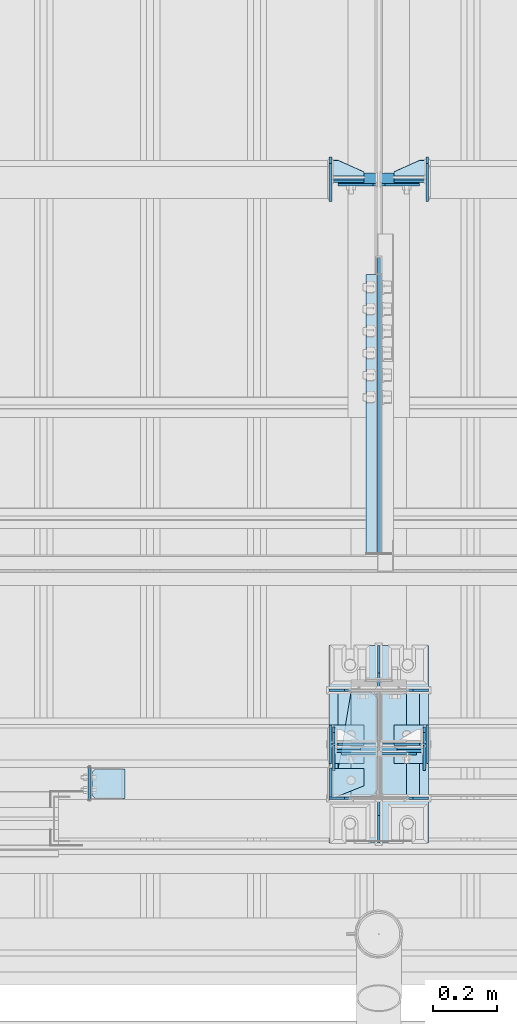
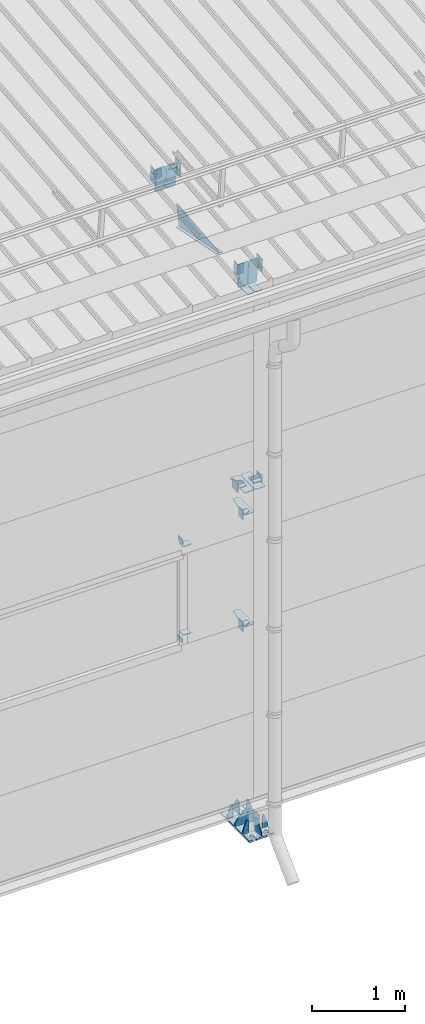
# One storey, part 143 of 709: 45 plates, 4 openings, 11 elements without a shape of their own.
"""IFC4 building model written with IfcOpenShell, lengths in millimetres."""

from ifc_helpers import new_model, si_unit, direction, frame, origin_with_axes, place, context, subcontext, project, spatial, line, arc, indexed_curve, outline, extrude, material, element, aggregate, save


model = new_model("IFC4")

# Units and contexts
model_context = context("Model", 3, precision=0.2, world=origin_with_axes(), true_north=direction((0.0, 1.0)))
body_context = subcontext(model_context, "Body", "Model", "MODEL_VIEW")
ifc_project = project(units=[si_unit("LENGTHUNIT", "METRE", prefix="MILLI"), si_unit("AREAUNIT", "SQUARE_METRE"), si_unit("VOLUMEUNIT", "CUBIC_METRE"), si_unit("MASSUNIT", "GRAM", prefix="KILO"), si_unit("TIMEUNIT", "SECOND"), si_unit("PLANEANGLEUNIT", "RADIAN"), si_unit("SOLIDANGLEUNIT", "STERADIAN"), si_unit("THERMODYNAMICTEMPERATUREUNIT", "DEGREE_CELSIUS"), si_unit("LUMINOUSINTENSITYUNIT", "LUMEN")], contexts=[model_context])

# Site, building, storey
site_placement = place(None, origin_with_axes())
site = spatial("IfcSite", under=ifc_project, at=site_placement, CompositionType="ELEMENT")
building_placement = place(site_placement, origin_with_axes())
building = spatial("IfcBuilding", under=site, at=building_placement, Name="Undefined", CompositionType="ELEMENT")
storey_placement = place(building_placement, origin_with_axes())
storey = spatial("IfcBuildingStorey", under=building, at=storey_placement, Name="Undefined", CompositionType="ELEMENT", Elevation=0.0)

# Assembly, plates, voiding features
assembly_1_placement = place(storey_placement, frame((34000.0, 173.0, -200.0), z_axis=(-1.0, 0.0, 0.0), x_axis=(0.0, 0.0, 1.0)))
assembly_1 = element("IfcElementAssembly", 1, at=assembly_1_placement, inside=storey)
ifc_material = material(Name="C355-6", Category="STEEL")
plate_1_placement = place(assembly_1_placement, frame((7434.21546, -30.02526, -3.0), z_axis=(0.099503719, 0.9950371902, 0.0), x_axis=(0.0, 0.0, -1.0)))
plate_1 = element("IfcPlate", 2, at=plate_1_placement, material=ifc_material, ObjectType="595", context=body_context, shape_type="SolidModel", body=[
    extrude(outline(indexed_curve([(0.0, 0.0), (114.0, 0.0), (114.0, 332.53554), (0.0, 332.53554)], segments=[line(1, 2, 3, 4, 1)])), frame((0.0, 0.0, 4.0), z_axis=(0.0, 0.0, 1.0), x_axis=(1.0, 0.0, 0.0)), (0.0, 0.0, -1.0), 8.0),
])
plate_2_placement = place(assembly_1_placement, frame((7434.21546, -30.02526, 3.0), z_axis=(-0.099503719, -0.9950371902, 0.0), x_axis=(0.0, 0.0, 1.0)))
plate_2 = element("IfcPlate", 3, at=plate_2_placement, material=ifc_material, ObjectType="595", context=body_context, shape_type="SolidModel", body=[
    extrude(outline(indexed_curve([(0.0, 0.0), (114.0, 0.0), (114.0, 333.33554), (0.0, 333.33554)], segments=[line(1, 2, 3, 4, 1)])), frame((0.0, 0.0, 4.0), z_axis=(0.0, 0.0, 1.0), x_axis=(1.0, 0.0, 0.0)), (0.0, 0.0, -1.0), 8.0),
])
plate_3_placement = place(assembly_1_placement, frame((4502.0, -163.0, -127.0), z_axis=(-1.0, 0.0, 0.0), x_axis=(0.0, 0.0, 1.0)))
plate_3 = element("IfcPlate", 4, at=plate_3_placement, material=ifc_material, ObjectType="547", context=body_context, shape_type="SolidModel", body=[
    extrude(outline(indexed_curve([(0.0, 0.0), (108.0, 0.0), (123.0, 15.0), (123.0, 311.0), (108.0, 326.0), (0.0, 326.0)], segments=[line(1, 2, 3, 4, 5, 6, 1)])), frame((0.0, 0.0, 4.0), z_axis=(0.0, 0.0, 1.0), x_axis=(1.0, 0.0, 0.0)), (0.0, 0.0, -1.0), 8.0),
])
plate_4_placement = place(assembly_1_placement, frame((4502.0, 163.0, 127.0), z_axis=(-1.0, 0.0, 0.0), x_axis=(0.0, 0.0, -1.0)))
plate_4 = element("IfcPlate", 5, at=plate_4_placement, material=ifc_material, ObjectType="547", context=body_context, shape_type="SolidModel", body=[
    extrude(outline(indexed_curve([(0.0, 0.0), (108.0, 0.0), (123.0, 15.0), (123.0, 311.0), (108.0, 326.0), (0.0, 326.0)], segments=[line(1, 2, 3, 4, 5, 6, 1)])), frame((0.0, 0.0, 4.0), z_axis=(0.0, 0.0, 1.0), x_axis=(1.0, 0.0, 0.0)), (0.0, 0.0, -1.0), 8.0),
])
plate_5_placement = place(assembly_1_placement, frame((4212.0, 163.0, 4.0), z_axis=(1.0, 0.0, 0.0), x_axis=(0.0, 0.0, 1.0)))
plate_5 = element("IfcPlate", 6, at=plate_5_placement, material=ifc_material, ObjectType="543", context=body_context, shape_type="SolidModel", body=[
    extrude(outline(indexed_curve([(0.0, 20.0), (20.0, 0.0), (83.0, 0.0), (123.0, 240.0), (123.0, 326.0), (20.0, 326.0), (0.0, 306.0)], segments=[line(1, 2, 3, 4, 5, 6, 7, 1)])), frame((0.0, 0.0, 4.0), z_axis=(0.0, 0.0, 1.0), x_axis=(1.0, 0.0, 0.0)), (0.0, 0.0, -1.0), 8.0),
])
plate_6_placement = place(assembly_1_placement, frame((2742.0, 163.0, 4.0), z_axis=(1.0, 0.0, 0.0), x_axis=(0.0, 0.0, 1.0)))
plate_6 = element("IfcPlate", 7, at=plate_6_placement, material=ifc_material, ObjectType="543", context=body_context, shape_type="SolidModel", body=[
    extrude(outline(indexed_curve([(0.0, 20.0), (20.0, 0.0), (83.0, 0.0), (123.0, 240.0), (123.0, 326.0), (20.0, 326.0), (0.0, 306.0)], segments=[line(1, 2, 3, 4, 5, 6, 7, 1)])), frame((0.0, 0.0, 4.0), z_axis=(0.0, 0.0, 1.0), x_axis=(1.0, 0.0, 0.0)), (0.0, 0.0, -1.0), 8.0),
])
plate_7_placement = place(assembly_1_placement, frame((7097.93718, 163.0, 87.0), z_axis=(-1.0, 0.0, 0.0), x_axis=(0.0, 0.0, -1.0)))
plate_7 = element("IfcPlate", 8, at=plate_7_placement, material=ifc_material, ObjectType="461", context=body_context, shape_type="SolidModel", body=[
    extrude(outline(indexed_curve([(0.0, 0.0), (68.0, 0.0), (83.0, 15.0), (83.0, 311.0), (68.0, 326.0), (0.0, 326.0)], segments=[line(1, 2, 3, 4, 5, 6, 1)])), frame((0.0, 0.0, 4.0), z_axis=(0.0, 0.0, 1.0), x_axis=(1.0, 0.0, 0.0)), (0.0, 0.0, -1.0), 8.0),
])
plate_8_placement = place(assembly_1_placement, frame((7097.93718, -163.0, -87.0), z_axis=(-1.0, 0.0, 0.0), x_axis=(0.0, 0.0, 1.0)))
plate_8 = element("IfcPlate", 9, at=plate_8_placement, material=ifc_material, ObjectType="461", context=body_context, shape_type="SolidModel", body=[
    extrude(outline(indexed_curve([(0.0, 0.0), (68.0, 0.0), (83.0, 15.0), (83.0, 311.0), (68.0, 326.0), (0.0, 326.0)], segments=[line(1, 2, 3, 4, 5, 6, 1)])), frame((0.0, 0.0, 4.0), z_axis=(0.0, 0.0, 1.0), x_axis=(1.0, 0.0, 0.0)), (0.0, 0.0, -1.0), 8.0),
])
plate_9_placement = place(assembly_1_placement, frame((12.5, -308.0, 155.0), z_axis=(1.0, 0.0, 0.0), x_axis=(0.0, 0.0, -1.0)))
plate_9 = element("IfcPlate", 10, at=plate_9_placement, material=ifc_material, ObjectType="416", context=body_context, shape_type="SolidModel", body=[
    extrude(outline(indexed_curve([(0.0, 0.0), (310.0, 0.0), (310.0, 616.0), (0.0, 616.0)], segments=[line(1, 2, 3, 4, 1)])), frame((0.0, 0.0, 12.5), z_axis=(0.0, 0.0, 1.0), x_axis=(1.0, 0.0, 0.0)), (0.0, 0.0, -1.0), 25.0),
])
voiding_feature_1_placement = place(plate_9_placement, frame((40.0, 616.0, 0.0), z_axis=(0.0, 0.0, -1.0), x_axis=(1.0, 0.0, 0.0)))
element("IfcVoidingFeature", 11, at=voiding_feature_1_placement, cuts=plate_9, PredefinedType="HOLE", context=body_context, shape_type="SolidModel", body=[
    extrude(outline(indexed_curve([(0.0, 0.0), (50.0, 0.0), (50.0, 60.0), (42.67767, 77.67767), (25.0, 85.0), (25.0, 85.0), (7.32233, 77.67767), (0.0, 60.0)], segments=[line(1, 2, 3), arc(3, 4, 5), line(5, 6), arc(6, 7, 8), line(8, 1)])), frame((0.0, 0.0, 12.5), z_axis=(0.0, 0.0, 1.0), x_axis=(1.0, 0.0, 0.0)), (0.0, 0.0, -1.0), 25.0),
])
voiding_feature_2_placement = place(plate_9_placement, frame((40.0, 0.0, 0.0), z_axis=(0.0, 0.0, 1.0), x_axis=(1.0, 0.0, 0.0)))
element("IfcVoidingFeature", 12, at=voiding_feature_2_placement, cuts=plate_9, PredefinedType="HOLE", context=body_context, shape_type="SolidModel", body=[
    extrude(outline(indexed_curve([(0.0, 0.0), (50.0, 0.0), (50.0, 60.0), (42.67767, 77.67767), (25.0, 85.0), (25.0, 85.0), (7.32233, 77.67767), (0.0, 60.0)], segments=[line(1, 2, 3), arc(3, 4, 5), line(5, 6), arc(6, 7, 8), line(8, 1)])), frame((0.0, 0.0, 12.5), z_axis=(0.0, 0.0, 1.0), x_axis=(1.0, 0.0, 0.0)), (0.0, 0.0, -1.0), 25.0),
])
voiding_feature_3_placement = place(plate_9_placement, frame((270.0, 616.0, 0.0), z_axis=(0.0, 0.0, 1.0), x_axis=(-1.0, 0.0, 0.0)))
element("IfcVoidingFeature", 13, at=voiding_feature_3_placement, cuts=plate_9, PredefinedType="HOLE", context=body_context, shape_type="SolidModel", body=[
    extrude(outline(indexed_curve([(0.0, 0.0), (50.0, 0.0), (50.0, 60.0), (42.67767, 77.67767), (25.0, 85.0), (25.0, 85.0), (7.32233, 77.67767), (0.0, 60.0)], segments=[line(1, 2, 3), arc(3, 4, 5), line(5, 6), arc(6, 7, 8), line(8, 1)])), frame((0.0, 0.0, 12.5), z_axis=(0.0, 0.0, 1.0), x_axis=(1.0, 0.0, 0.0)), (0.0, 0.0, -1.0), 25.0),
])
voiding_feature_4_placement = place(plate_9_placement, frame((270.0, 0.0, 0.0), z_axis=(0.0, 0.0, -1.0), x_axis=(-1.0, 0.0, 0.0)))
element("IfcVoidingFeature", 14, at=voiding_feature_4_placement, cuts=plate_9, PredefinedType="HOLE", context=body_context, shape_type="SolidModel", body=[
    extrude(outline(indexed_curve([(0.0, 0.0), (50.0, 0.0), (50.0, 60.0), (42.67767, 77.67767), (25.0, 85.0), (25.0, 85.0), (7.32233, 77.67767), (0.0, 60.0)], segments=[line(1, 2, 3), arc(3, 4, 5), line(5, 6), arc(6, 7, 8), line(8, 1)])), frame((0.0, 0.0, 12.5), z_axis=(0.0, 0.0, 1.0), x_axis=(1.0, 0.0, 0.0)), (0.0, 0.0, -1.0), 25.0),
])
plate_10_placement = place(assembly_1_placement, frame((25.0, -168.5, 87.0), z_axis=(0.0, 1.0, 0.0), x_axis=(0.0, 0.0, 1.0)))
plate_10 = element("IfcPlate", 15, at=plate_10_placement, material=ifc_material, ObjectType="419", context=body_context, shape_type="SolidModel", body=[
    extrude(outline(indexed_curve([(0.0, 0.0), (68.0, 0.0), (68.0, 50.0), (20.0, 175.0), (0.0, 175.0)], segments=[line(1, 2, 3, 4, 5, 1)])), frame((0.0, 0.0, 4.0), z_axis=(0.0, 0.0, 1.0), x_axis=(1.0, 0.0, 0.0)), (0.0, 0.0, -1.0), 8.0),
])
plate_11_placement = place(assembly_1_placement, frame((25.0, 0.0, 3.0), z_axis=(0.0, 1.0, 0.0), x_axis=(0.0, 0.0, 1.0)))
plate_11 = element("IfcPlate", 16, at=plate_11_placement, material=ifc_material, ObjectType="417", context=body_context, shape_type="SolidModel", body=[
    extrude(outline(indexed_curve([(0.0, 0.0), (152.0, 0.0), (152.0, 50.0), (50.0, 175.0), (0.0, 175.0)], segments=[line(1, 2, 3, 4, 5, 1)])), frame((0.0, 0.0, 4.0), z_axis=(0.0, 0.0, 1.0), x_axis=(1.0, 0.0, 0.0)), (0.0, 0.0, -1.0), 8.0),
])
plate_12_placement = place(assembly_1_placement, frame((25.0, 173.0, 0.0), z_axis=(0.0, 0.0, -1.0), x_axis=(0.0, 1.0, 0.0)))
plate_12 = element("IfcPlate", 17, at=plate_12_placement, material=ifc_material, ObjectType="418", context=body_context, shape_type="SolidModel", body=[
    extrude(outline(indexed_curve([(0.0, 0.0), (135.0, 0.0), (135.0, 50.0), (50.0, 175.0), (0.0, 175.0)], segments=[line(1, 2, 3, 4, 5, 1)])), frame((0.0, 0.0, 4.0), z_axis=(0.0, 0.0, 1.0), x_axis=(1.0, 0.0, 0.0)), (0.0, 0.0, -1.0), 8.0),
])
plate_13_placement = place(assembly_1_placement, frame((25.0, 0.0, -3.0), z_axis=(0.0, -1.0, 0.0), x_axis=(0.0, 0.0, -1.0)))
plate_13 = element("IfcPlate", 18, at=plate_13_placement, material=ifc_material, ObjectType="417", context=body_context, shape_type="SolidModel", body=[
    extrude(outline(indexed_curve([(0.0, 0.0), (152.0, 0.0), (152.0, 50.0), (50.0, 175.0), (0.0, 175.0)], segments=[line(1, 2, 3, 4, 5, 1)])), frame((0.0, 0.0, 4.0), z_axis=(0.0, 0.0, 1.0), x_axis=(1.0, 0.0, 0.0)), (0.0, 0.0, -1.0), 8.0),
])
plate_14_placement = place(assembly_1_placement, frame((25.0, -173.0, 0.0), z_axis=(0.0, 0.0, 1.0), x_axis=(0.0, -1.0, 0.0)))
plate_14 = element("IfcPlate", 19, at=plate_14_placement, material=ifc_material, ObjectType="418", context=body_context, shape_type="SolidModel", body=[
    extrude(outline(indexed_curve([(0.0, 0.0), (135.0, 0.0), (135.0, 50.0), (50.0, 175.0), (0.0, 175.0)], segments=[line(1, 2, 3, 4, 5, 1)])), frame((0.0, 0.0, 4.0), z_axis=(0.0, 0.0, 1.0), x_axis=(1.0, 0.0, 0.0)), (0.0, 0.0, -1.0), 8.0),
])
plate_15_placement = place(assembly_1_placement, frame((25.0, -168.5, -87.0), z_axis=(0.0, -1.0, 0.0), x_axis=(0.0, 0.0, -1.0)))
plate_15 = element("IfcPlate", 20, at=plate_15_placement, material=ifc_material, ObjectType="419", context=body_context, shape_type="SolidModel", body=[
    extrude(outline(indexed_curve([(0.0, 0.0), (68.0, 0.0), (68.0, 50.0), (20.0, 175.0), (0.0, 175.0)], segments=[line(1, 2, 3, 4, 5, 1)])), frame((0.0, 0.0, 4.0), z_axis=(0.0, 0.0, 1.0), x_axis=(1.0, 0.0, 0.0)), (0.0, 0.0, -1.0), 8.0),
])
plate_16_placement = place(assembly_1_placement, frame((25.0, 168.5, -87.0), z_axis=(0.0, -1.0, 0.0), x_axis=(0.0, 0.0, -1.0)))
plate_16 = element("IfcPlate", 21, at=plate_16_placement, material=ifc_material, ObjectType="419", context=body_context, shape_type="SolidModel", body=[
    extrude(outline(indexed_curve([(0.0, 0.0), (68.0, 0.0), (68.0, 50.0), (20.0, 175.0), (0.0, 175.0)], segments=[line(1, 2, 3, 4, 5, 1)])), frame((0.0, 0.0, 4.0), z_axis=(0.0, 0.0, 1.0), x_axis=(1.0, 0.0, 0.0)), (0.0, 0.0, -1.0), 8.0),
])
plate_17_placement = place(assembly_1_placement, frame((25.0, 168.5, 87.0), z_axis=(0.0, 1.0, 0.0), x_axis=(0.0, 0.0, 1.0)))
plate_17 = element("IfcPlate", 22, at=plate_17_placement, material=ifc_material, ObjectType="419", context=body_context, shape_type="SolidModel", body=[
    extrude(outline(indexed_curve([(0.0, 0.0), (68.0, 0.0), (68.0, 50.0), (20.0, 175.0), (0.0, 175.0)], segments=[line(1, 2, 3, 4, 5, 1)])), frame((0.0, 0.0, 4.0), z_axis=(0.0, 0.0, 1.0), x_axis=(1.0, 0.0, 0.0)), (0.0, 0.0, -1.0), 8.0),
])
aggregate(assembly_1, [plate_1, plate_2, plate_3, plate_4, plate_5, plate_6, plate_7, plate_8, plate_9, plate_10, plate_11, plate_12, plate_13, plate_14, plate_15, plate_16, plate_17])

# Assembly, plates
assembly_2_placement = place(storey_placement, frame((34000.0, 346.0, 7089.70002), z_axis=(1.0, 0.0, 0.0), x_axis=(0.0, 0.9950371902, 0.099503719)))
assembly_2 = element("IfcElementAssembly", 23, at=assembly_2_placement, inside=storey)
plate_18_placement = place(assembly_2_placement, frame((1597.88359, 163.0, 127.0), z_axis=(-1.0, 0.0, 0.0), x_axis=(0.0, 0.0, -1.0)))
plate_18 = element("IfcPlate", 24, at=plate_18_placement, material=ifc_material, ObjectType="585", context=body_context, shape_type="SolidModel", body=[
    extrude(outline(indexed_curve([(0.0, 0.0), (108.0, 0.0), (123.0, 15.0), (123.0, 311.0), (108.0, 326.0), (0.0, 326.0)], segments=[line(1, 2, 3, 4, 5, 6, 1)])), frame((0.0, 0.0, 4.0), z_axis=(0.0, 0.0, 1.0), x_axis=(1.0, 0.0, 0.0)), (0.0, 0.0, -1.0), 8.0),
])
plate_19_placement = place(assembly_2_placement, frame((1597.88359, 163.0, -127.0), z_axis=(1.0, 0.0, 0.0), x_axis=(0.0, 0.0, 1.0)))
plate_19 = element("IfcPlate", 25, at=plate_19_placement, material=ifc_material, ObjectType="585", context=body_context, shape_type="SolidModel", body=[
    extrude(outline(indexed_curve([(0.0, 0.0), (108.0, 0.0), (123.0, 15.0), (123.0, 311.0), (108.0, 326.0), (0.0, 326.0)], segments=[line(1, 2, 3, 4, 5, 6, 1)])), frame((0.0, 0.0, 4.0), z_axis=(0.0, 0.0, 1.0), x_axis=(1.0, 0.0, 0.0)), (0.0, 0.0, -1.0), 8.0),
])
plate_20_placement = place(assembly_2_placement, frame((1255.8048, -434.94249, -40.0), z_axis=(0.2927142719, 0.9561999556, 0.0), x_axis=(-0.9561999556, 0.2927142719, 0.0)))
plate_20 = element("IfcPlate", 26, at=plate_20_placement, material=ifc_material, ObjectType="450", context=body_context, shape_type="SolidModel", body=[
    extrude(outline(indexed_curve([(0.0, 0.0), (887.65935, 0.0), (887.65935, 80.0), (0.0, 80.0)], segments=[line(1, 2, 3, 4, 1)])), frame((0.0, 0.0, 4.0), z_axis=(0.0, 0.0, 1.0), x_axis=(1.0, 0.0, 0.0)), (0.0, 0.0, -1.0), 8.0),
])
plate_21_placement = place(assembly_2_placement, frame((1336.51563, -171.28713, 0.0), z_axis=(0.0, 0.0, 1.0), x_axis=(-1.0, 0.0, 0.0)))
plate_21 = element("IfcPlate", 27, at=plate_21_placement, material=ifc_material, ObjectType="449", context=body_context, shape_type="SolidModel", body=[
    extrude(outline(indexed_curve([(0.0, 0.0), (928.3198, 0.0), (79.53997, 259.83056)], segments=[line(1, 2, 3, 1)])), frame((0.0, 0.0, 6.0), z_axis=(0.0, 0.0, 1.0), x_axis=(1.0, 0.0, 0.0)), (0.0, 0.0, -1.0), 12.0),
])
aggregate(assembly_2, [plate_18, plate_19, plate_20, plate_21])

assembly_3_placement = place(storey_placement, frame((28000.0, 50.0, 2550.0), z_axis=(0.0, 0.0, -1.0), x_axis=(1.0, 0.0, 0.0)))
assembly_3 = element("IfcElementAssembly", 28, at=assembly_3_placement, inside=storey)
plate_22_placement = place(assembly_3_placement, frame((5849.0, 47.0, -60.0), z_axis=(-1.0, 0.0, 0.0), x_axis=(0.0, -1.0, 0.0)))
plate_22 = element("IfcPlate", 29, at=plate_22_placement, material=ifc_material, ObjectType="501", context=body_context, shape_type="SolidModel", body=[
    extrude(outline(indexed_curve([(0.0, 0.0), (94.0, 0.0), (94.0, 120.0), (0.0, 120.0)], segments=[line(1, 2, 3, 4, 1)])), frame((0.0, 0.0, 4.0), z_axis=(0.0, 0.0, 1.0), x_axis=(1.0, 0.0, 0.0)), (0.0, 0.0, -1.0), 8.0),
])
plate_23_placement = place(assembly_3_placement, frame((5853.0, 47.0, 0.0), z_axis=(0.0, 0.0, 1.0), x_axis=(0.0, -1.0, 0.0)))
plate_23 = element("IfcPlate", 30, at=plate_23_placement, material=ifc_material, ObjectType="502", context=body_context, shape_type="SolidModel", body=[
    extrude(outline(indexed_curve([(0.0, 0.0), (94.0, 0.0), (94.0, 100.0), (40.0, 100.0), (0.0, 0.0)], segments=[line(1, 2, 3, 4, 5, 1)])), frame((0.0, 0.0, 4.0), z_axis=(0.0, 0.0, 1.0), x_axis=(1.0, 0.0, 0.0)), (0.0, 0.0, -1.0), 8.0),
])
plate_24_placement = place(assembly_3_placement, frame((5096.0, 50.0, -50.0), z_axis=(-1.0, 0.0, 0.0), x_axis=(0.0, 0.0, -1.0)))
plate_24 = element("IfcPlate", 31, at=plate_24_placement, material=ifc_material, ObjectType="509", context=body_context, shape_type="SolidModel", body=[
    extrude(outline(indexed_curve([(0.0, 0.0), (65.0, 0.0), (65.0, 100.0), (0.0, 100.0)], segments=[line(1, 2, 3, 4, 1)])), frame((0.0, 0.0, 4.0), z_axis=(0.0, 0.0, 1.0), x_axis=(1.0, 0.0, 0.0)), (0.0, 0.0, -1.0), 8.0),
])
aggregate(assembly_3, [plate_22, plate_23, plate_24])

assembly_4_placement = place(storey_placement, frame((28000.0, 50.0, 4020.0), z_axis=(0.0, 0.0, -1.0), x_axis=(1.0, 0.0, 0.0)))
assembly_4 = element("IfcElementAssembly", 32, at=assembly_4_placement, inside=storey)
plate_25_placement = place(assembly_4_placement, frame((5096.0, -50.0, 50.0), z_axis=(-1.0, 0.0, 0.0), x_axis=(0.0, 0.0, 1.0)))
plate_25 = element("IfcPlate", 33, at=plate_25_placement, material=ifc_material, ObjectType="509", context=body_context, shape_type="SolidModel", body=[
    extrude(outline(indexed_curve([(0.0, 0.0), (65.0, 0.0), (65.0, 100.0), (0.0, 100.0)], segments=[line(1, 2, 3, 4, 1)])), frame((0.0, 0.0, 4.0), z_axis=(0.0, 0.0, 1.0), x_axis=(1.0, 0.0, 0.0)), (0.0, 0.0, -1.0), 8.0),
])
plate_26_placement = place(assembly_4_placement, frame((5853.0, 47.0, 0.0), z_axis=(0.0, 0.0, 1.0), x_axis=(0.0, -1.0, 0.0)))
plate_26 = element("IfcPlate", 34, at=plate_26_placement, material=ifc_material, ObjectType="502", context=body_context, shape_type="SolidModel", body=[
    extrude(outline(indexed_curve([(0.0, 0.0), (94.0, 0.0), (94.0, 100.0), (40.0, 100.0), (0.0, 0.0)], segments=[line(1, 2, 3, 4, 5, 1)])), frame((0.0, 0.0, 4.0), z_axis=(0.0, 0.0, 1.0), x_axis=(1.0, 0.0, 0.0)), (0.0, 0.0, -1.0), 8.0),
])
plate_27_placement = place(assembly_4_placement, frame((5849.0, 47.0, -60.0), z_axis=(-1.0, 0.0, 0.0), x_axis=(0.0, -1.0, 0.0)))
plate_27 = element("IfcPlate", 35, at=plate_27_placement, material=ifc_material, ObjectType="501", context=body_context, shape_type="SolidModel", body=[
    extrude(outline(indexed_curve([(0.0, 0.0), (94.0, 0.0), (94.0, 120.0), (0.0, 120.0)], segments=[line(1, 2, 3, 4, 1)])), frame((0.0, 0.0, 4.0), z_axis=(0.0, 0.0, 1.0), x_axis=(1.0, 0.0, 0.0)), (0.0, 0.0, -1.0), 8.0),
])
aggregate(assembly_4, [plate_25, plate_26, plate_27])

assembly_5_placement = place(storey_placement, frame((33150.0, 50.0, 2600.0), z_axis=(1.0, 0.0, 0.0), x_axis=(0.0, 0.0, 1.0)))
assembly_5 = element("IfcElementAssembly", 36, at=assembly_5_placement, inside=storey)
plate_28_placement = place(assembly_5_placement, frame((103.0, 46.0, -46.0), z_axis=(-1.0, 0.0, 0.0), x_axis=(0.0, -1.0, 0.0)))
plate_28 = element("IfcPlate", 37, at=plate_28_placement, material=ifc_material, ObjectType="510", context=body_context, shape_type="SolidModel", body=[
    extrude(outline(indexed_curve([(0.0, 10.0), (10.0, 0.0), (82.0, 0.0), (92.0, 10.0), (92.0, 104.0), (0.0, 104.0)], segments=[line(1, 2, 3, 4, 5, 6, 1)])), frame((0.0, 0.0, 4.0), z_axis=(0.0, 0.0, 1.0), x_axis=(1.0, 0.0, 0.0)), (0.0, 0.0, -1.0), 8.0),
])
plate_29_placement = place(assembly_5_placement, frame((1267.0, -46.0, -46.0), z_axis=(1.0, 0.0, 0.0), x_axis=(0.0, 1.0, 0.0)))
plate_29 = element("IfcPlate", 38, at=plate_29_placement, material=ifc_material, ObjectType="510", context=body_context, shape_type="SolidModel", body=[
    extrude(outline(indexed_curve([(0.0, 10.0), (10.0, 0.0), (82.0, 0.0), (92.0, 10.0), (92.0, 104.0), (0.0, 104.0)], segments=[line(1, 2, 3, 4, 5, 6, 1)])), frame((0.0, 0.0, 4.0), z_axis=(0.0, 0.0, 1.0), x_axis=(1.0, 0.0, 0.0)), (0.0, 0.0, -1.0), 8.0),
])
aggregate(assembly_5, [plate_28, plate_29])

assembly_6_placement = place(storey_placement, frame((28000.0, 173.0, 4310.0), z_axis=(0.0, 0.0, -1.0), x_axis=(1.0, 0.0, 0.0)))
assembly_6 = element("IfcElementAssembly", 39, at=assembly_6_placement, inside=storey)
plate_30_placement = place(assembly_6_placement, frame((5849.0, -60.0, 60.0), z_axis=(1.0, 0.0, 0.0), x_axis=(0.0, 0.0, -1.0)))
plate_30 = element("IfcPlate", 40, at=plate_30_placement, material=ifc_material, ObjectType="506", context=body_context, shape_type="SolidModel", body=[
    extrude(outline(indexed_curve([(0.0, 0.0), (120.0, 0.0), (120.0, 120.0), (0.0, 120.0)], segments=[line(1, 2, 3, 4, 1)])), frame((0.0, 0.0, 4.0), z_axis=(0.0, 0.0, 1.0), x_axis=(1.0, 0.0, 0.0)), (0.0, 0.0, -1.0), 8.0),
])
plate_31_placement = place(assembly_6_placement, frame((5953.0, -60.0, 0.0), z_axis=(0.0, 0.0, 1.0), x_axis=(0.0, 1.0, 0.0)))
plate_31 = element("IfcPlate", 41, at=plate_31_placement, material=ifc_material, ObjectType="507", context=body_context, shape_type="SolidModel", body=[
    extrude(outline(indexed_curve([(0.0, 0.0), (120.0, 0.0), (120.0, 100.0), (0.0, 100.0)], segments=[line(1, 2, 3, 4, 1)])), frame((0.0, 0.0, 4.0), z_axis=(0.0, 0.0, 1.0), x_axis=(1.0, 0.0, 0.0)), (0.0, 0.0, -1.0), 8.0),
])
plate_32_placement = place(assembly_6_placement, frame((5953.0, 0.0, -60.0), z_axis=(0.0, -1.0, 0.0), x_axis=(0.0, 0.0, 1.0)))
plate_32 = element("IfcPlate", 42, at=plate_32_placement, material=ifc_material, ObjectType="508", context=body_context, shape_type="SolidModel", body=[
    extrude(outline(indexed_curve([(0.0, 80.0), (36.0, 0.0), (56.0, 0.0), (56.0, 90.0), (46.0, 100.0), (0.0, 100.0)], segments=[line(1, 2, 3, 4, 5, 6, 1)])), frame((0.0, 0.0, 4.0), z_axis=(0.0, 0.0, 1.0), x_axis=(1.0, 0.0, 0.0)), (0.0, 0.0, -1.0), 8.0),
])
aggregate(assembly_6, [plate_30, plate_31, plate_32])

assembly_7_placement = place(storey_placement, frame((34000.0, 173.0, 4310.0), z_axis=(0.0, 0.0, -1.0), x_axis=(1.0, 0.0, 0.0)))
assembly_7 = element("IfcElementAssembly", 43, at=assembly_7_placement, inside=storey)
plate_33_placement = place(assembly_7_placement, frame((47.0, 0.0, -60.0), z_axis=(0.0, 1.0, 0.0), x_axis=(0.0, 0.0, 1.0)))
plate_33 = element("IfcPlate", 44, at=plate_33_placement, material=ifc_material, ObjectType="508", context=body_context, shape_type="SolidModel", body=[
    extrude(outline(indexed_curve([(0.0, 80.0), (36.0, 0.0), (56.0, 0.0), (56.0, 90.0), (46.0, 100.0), (0.0, 100.0)], segments=[line(1, 2, 3, 4, 5, 6, 1)])), frame((0.0, 0.0, 4.0), z_axis=(0.0, 0.0, 1.0), x_axis=(1.0, 0.0, 0.0)), (0.0, 0.0, -1.0), 8.0),
])
plate_34_placement = place(assembly_7_placement, frame((151.0, 60.0, 60.0), z_axis=(-1.0, 0.0, 0.0), x_axis=(0.0, 0.0, -1.0)))
plate_34 = element("IfcPlate", 45, at=plate_34_placement, material=ifc_material, ObjectType="506", context=body_context, shape_type="SolidModel", body=[
    extrude(outline(indexed_curve([(0.0, 0.0), (120.0, 0.0), (120.0, 120.0), (0.0, 120.0)], segments=[line(1, 2, 3, 4, 1)])), frame((0.0, 0.0, 4.0), z_axis=(0.0, 0.0, 1.0), x_axis=(1.0, 0.0, 0.0)), (0.0, 0.0, -1.0), 8.0),
])
plate_35_placement = place(assembly_7_placement, frame((47.0, 60.0, 0.0), z_axis=(0.0, 0.0, 1.0), x_axis=(0.0, -1.0, 0.0)))
plate_35 = element("IfcPlate", 46, at=plate_35_placement, material=ifc_material, ObjectType="507", context=body_context, shape_type="SolidModel", body=[
    extrude(outline(indexed_curve([(0.0, 0.0), (120.0, 0.0), (120.0, 100.0), (0.0, 100.0)], segments=[line(1, 2, 3, 4, 1)])), frame((0.0, 0.0, 4.0), z_axis=(0.0, 0.0, 1.0), x_axis=(1.0, 0.0, 0.0)), (0.0, 0.0, -1.0), 8.0),
])
aggregate(assembly_7, [plate_33, plate_34, plate_35])

assembly_8_placement = place(storey_placement, frame((28000.0, 158.95533, 7154.40952), z_axis=(0.0, 0.9950371902, 0.099503719), x_axis=(1.0, 0.0, 0.0)))
assembly_8 = element("IfcElementAssembly", 47, at=assembly_8_placement, inside=storey)
plate_36_placement = place(assembly_8_placement, frame((5859.0, -87.0, 60.0), z_axis=(1.0, 0.0, 0.0), x_axis=(0.0, 0.0, -1.0)))
plate_36 = element("IfcPlate", 48, at=plate_36_placement, material=ifc_material, ObjectType="596", context=body_context, shape_type="SolidModel", body=[
    extrude(outline(indexed_curve([(0.0, 0.0), (120.0, 0.0), (120.0, 174.0), (0.0, 174.0)], segments=[line(1, 2, 3, 4, 1)])), frame((0.0, 0.0, 4.0), z_axis=(0.0, 0.0, 1.0), x_axis=(1.0, 0.0, 0.0)), (0.0, 0.0, -1.0), 8.0),
])
plate_37_placement = place(assembly_8_placement, frame((5943.0, 72.0, 0.0), z_axis=(0.0, 0.0, 1.0), x_axis=(-1.0, 0.0, 0.0)))
plate_37 = element("IfcPlate", 49, at=plate_37_placement, material=ifc_material, ObjectType="597", context=body_context, shape_type="SolidModel", body=[
    extrude(outline(indexed_curve([(0.0, 0.0), (80.0, 0.0), (80.0, 144.0), (0.0, 144.0)], segments=[line(1, 2, 3, 4, 1)])), frame((0.0, 0.0, 4.0), z_axis=(0.0, 0.0, 1.0), x_axis=(1.0, 0.0, 0.0)), (0.0, 0.0, -1.0), 8.0),
])
aggregate(assembly_8, [plate_36, plate_37])

assembly_9_placement = place(storey_placement, frame((28000.0, 1936.65012, 7322.12913), z_axis=(0.0, 0.9950371902, 0.099503719), x_axis=(1.0, 0.0, 0.0)))
assembly_9 = element("IfcElementAssembly", 50, at=assembly_9_placement, inside=storey)
plate_38_placement = place(assembly_9_placement, frame((5953.0, 0.0, 60.0), z_axis=(0.0, -1.0, 0.0), x_axis=(-1.0, 0.0, 0.0)))
plate_38 = element("IfcPlate", 51, at=plate_38_placement, material=ifc_material, ObjectType="588", context=body_context, shape_type="SolidModel", body=[
    extrude(outline(indexed_curve([(0.0, 36.0), (80.0, 0.0), (100.0, 0.0), (100.0, 56.0), (0.0, 56.0)], segments=[line(1, 2, 3, 4, 5, 1)])), frame((0.0, 0.0, 4.0), z_axis=(0.0, 0.0, 1.0), x_axis=(1.0, 0.0, 0.0)), (0.0, 0.0, -1.0), 8.0),
])
plate_39_placement = place(assembly_9_placement, frame((5953.0, 65.0, 0.0), z_axis=(0.0, 0.0, 1.0), x_axis=(-1.0, 0.0, 0.0)))
plate_39 = element("IfcPlate", 52, at=plate_39_placement, material=ifc_material, ObjectType="587", context=body_context, shape_type="SolidModel", body=[
    extrude(outline(indexed_curve([(0.0, 0.0), (100.0, 0.0), (100.0, 130.0), (0.0, 130.0)], segments=[line(1, 2, 3, 4, 1)])), frame((0.0, 0.0, 4.0), z_axis=(0.0, 0.0, 1.0), x_axis=(1.0, 0.0, 0.0)), (0.0, 0.0, -1.0), 8.0),
])
plate_40_placement = place(assembly_9_placement, frame((5849.0, -98.0, 60.0), z_axis=(1.0, 0.0, 0.0), x_axis=(0.0, 0.0, -1.0)))
plate_40 = element("IfcPlate", 53, at=plate_40_placement, material=ifc_material, ObjectType="586", context=body_context, shape_type="SolidModel", body=[
    extrude(outline(indexed_curve([(0.0, 0.0), (120.0, 0.0), (120.0, 196.0), (0.0, 196.0)], segments=[line(1, 2, 3, 4, 1)])), frame((0.0, 0.0, 4.0), z_axis=(0.0, 0.0, 1.0), x_axis=(1.0, 0.0, 0.0)), (0.0, 0.0, -1.0), 8.0),
])
aggregate(assembly_9, [plate_38, plate_39, plate_40])

assembly_10_placement = place(storey_placement, frame((34000.0, 158.95533, 7154.40952), z_axis=(0.0, 0.9950371902, 0.099503719), x_axis=(1.0, 0.0, 0.0)))
assembly_10 = element("IfcElementAssembly", 54, at=assembly_10_placement, inside=storey)
plate_41_placement = place(assembly_10_placement, frame((57.0, -72.0, 0.0), z_axis=(0.0, 0.0, 1.0), x_axis=(1.0, 0.0, 0.0)))
plate_41 = element("IfcPlate", 55, at=plate_41_placement, material=ifc_material, ObjectType="597", context=body_context, shape_type="SolidModel", body=[
    extrude(outline(indexed_curve([(0.0, 0.0), (80.0, 0.0), (80.0, 144.0), (0.0, 144.0)], segments=[line(1, 2, 3, 4, 1)])), frame((0.0, 0.0, 4.0), z_axis=(0.0, 0.0, 1.0), x_axis=(1.0, 0.0, 0.0)), (0.0, 0.0, -1.0), 8.0),
])
plate_42_placement = place(assembly_10_placement, frame((141.0, -87.0, -60.0), z_axis=(-1.0, 0.0, 0.0), x_axis=(0.0, 0.0, 1.0)))
plate_42 = element("IfcPlate", 56, at=plate_42_placement, material=ifc_material, ObjectType="596", context=body_context, shape_type="SolidModel", body=[
    extrude(outline(indexed_curve([(0.0, 0.0), (120.0, 0.0), (120.0, 174.0), (0.0, 174.0)], segments=[line(1, 2, 3, 4, 1)])), frame((0.0, 0.0, 4.0), z_axis=(0.0, 0.0, 1.0), x_axis=(1.0, 0.0, 0.0)), (0.0, 0.0, -1.0), 8.0),
])
aggregate(assembly_10, [plate_41, plate_42])

assembly_11_placement = place(storey_placement, frame((34000.0, 1936.65012, 7322.12913), z_axis=(0.0, 0.9950371902, 0.099503719), x_axis=(1.0, 0.0, 0.0)))
assembly_11 = element("IfcElementAssembly", 57, at=assembly_11_placement, inside=storey)
plate_43_placement = place(assembly_11_placement, frame((47.0, 0.0, 60.0), z_axis=(0.0, 1.0, 0.0), x_axis=(1.0, 0.0, 0.0)))
plate_43 = element("IfcPlate", 58, at=plate_43_placement, material=ifc_material, ObjectType="588", context=body_context, shape_type="SolidModel", body=[
    extrude(outline(indexed_curve([(0.0, 36.0), (80.0, 0.0), (100.0, 0.0), (100.0, 56.0), (0.0, 56.0)], segments=[line(1, 2, 3, 4, 5, 1)])), frame((0.0, 0.0, 4.0), z_axis=(0.0, 0.0, 1.0), x_axis=(1.0, 0.0, 0.0)), (0.0, 0.0, -1.0), 8.0),
])
plate_44_placement = place(assembly_11_placement, frame((47.0, -65.0, 0.0), z_axis=(0.0, 0.0, 1.0), x_axis=(1.0, 0.0, 0.0)))
plate_44 = element("IfcPlate", 59, at=plate_44_placement, material=ifc_material, ObjectType="587", context=body_context, shape_type="SolidModel", body=[
    extrude(outline(indexed_curve([(0.0, 0.0), (100.0, 0.0), (100.0, 130.0), (0.0, 130.0)], segments=[line(1, 2, 3, 4, 1)])), frame((0.0, 0.0, 4.0), z_axis=(0.0, 0.0, 1.0), x_axis=(1.0, 0.0, 0.0)), (0.0, 0.0, -1.0), 8.0),
])
plate_45_placement = place(assembly_11_placement, frame((151.0, -98.0, -60.0), z_axis=(-1.0, 0.0, 0.0), x_axis=(0.0, 0.0, 1.0)))
plate_45 = element("IfcPlate", 60, at=plate_45_placement, material=ifc_material, ObjectType="586", context=body_context, shape_type="SolidModel", body=[
    extrude(outline(indexed_curve([(0.0, 0.0), (120.0, 0.0), (120.0, 196.0), (0.0, 196.0)], segments=[line(1, 2, 3, 4, 1)])), frame((0.0, 0.0, 4.0), z_axis=(0.0, 0.0, 1.0), x_axis=(1.0, 0.0, 0.0)), (0.0, 0.0, -1.0), 8.0),
])
aggregate(assembly_11, [plate_43, plate_44, plate_45])

save(model, "model.ifc")
